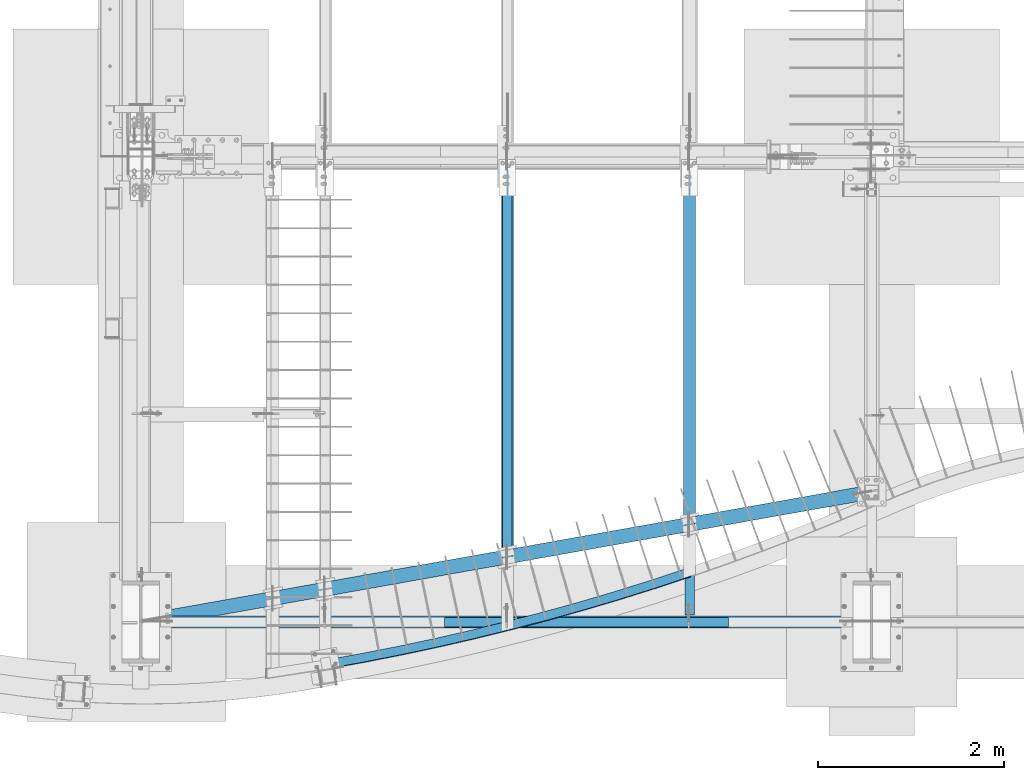
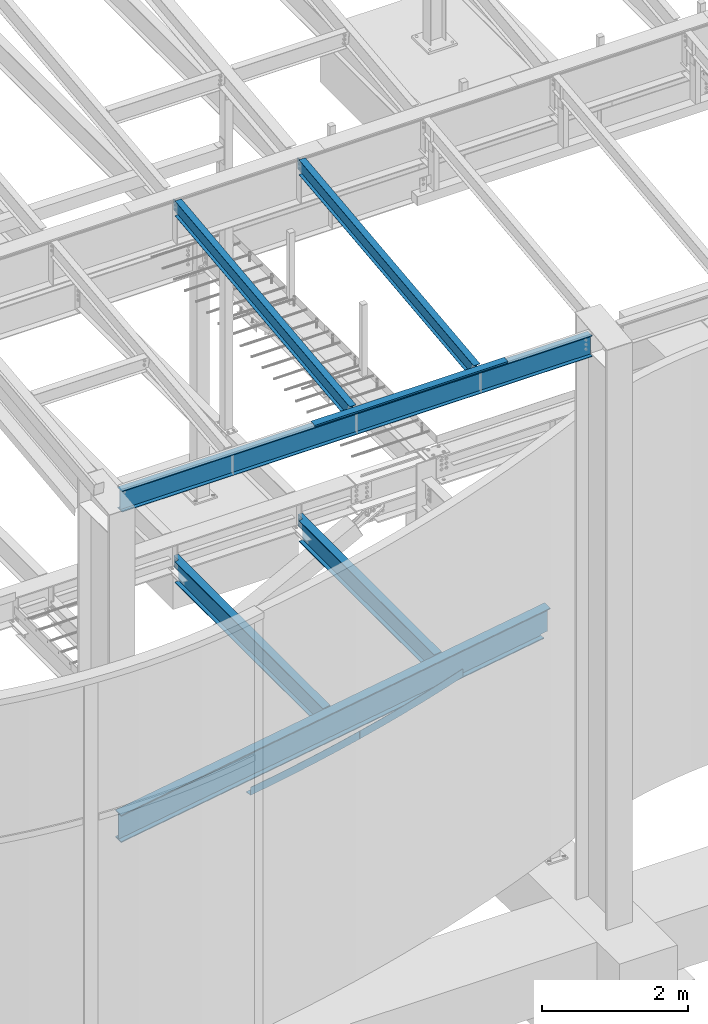
# One storey, part 703 of 1179: 9 beams, 8 elements without a shape of their own.
"""IFC2X3 building model written with IfcOpenShell, lengths in millimetres."""

from ifc_helpers import new_model, si_unit, frame, origin_with_axes, place, context, subcontext, project, spatial, faceted_brep, material, type_object, element, aggregate, save


model = new_model("IFC2X3")

# Units and contexts
model_context = context("Model", 3, precision=1e-05, world=origin_with_axes())
body_context = subcontext(model_context, "Body", "Model", "MODEL_VIEW")
ifc_project = project(units=[si_unit("LENGTHUNIT", "METRE", prefix="MILLI"), si_unit("AREAUNIT", "SQUARE_METRE"), si_unit("VOLUMEUNIT", "CUBIC_METRE"), si_unit("MASSUNIT", "GRAM", prefix="KILO"), si_unit("TIMEUNIT", "SECOND"), si_unit("PLANEANGLEUNIT", "RADIAN"), si_unit("SOLIDANGLEUNIT", "STERADIAN"), si_unit("THERMODYNAMICTEMPERATUREUNIT", "DEGREE_CELSIUS"), si_unit("LUMINOUSINTENSITYUNIT", "LUMEN")], contexts=[model_context])

# Site, building, storey
site_placement = place(None, origin_with_axes())
site = spatial("IfcSite", under=ifc_project, at=site_placement, CompositionType="ELEMENT")
building_placement = place(site_placement, origin_with_axes())
building = spatial("IfcBuilding", under=site, at=building_placement, Name="Undefined", CompositionType="ELEMENT")
storey_placement = place(building_placement, origin_with_axes())
storey = spatial("IfcBuildingStorey", under=building, at=storey_placement, Name="Undefined", CompositionType="ELEMENT", Elevation=0.0)

# Assembly, beam
assembly_1_placement = place(storey_placement, origin_with_axes())
assembly_1 = element("IfcElementAssembly", 1, at=assembly_1_placement, inside=storey, Name="BEAM", AssemblyPlace="NOTDEFINED", PredefinedType="RIGID_FRAME")
ifc_material_1 = material(Name="STEEL/A992")
beam_type_1 = type_object("IfcBeamType", Name="W10X12", PredefinedType="NOTDEFINED")
beam_1_placement = place(assembly_1_placement, frame((6324.6, 452.231593993459, 9171.78056384809), z_axis=(-3.89779463887408e-08, -0.112282221021699, 0.993676357192035), x_axis=(0.0, 0.993676357192036, 0.112282221021699)))
beam_1 = element("IfcBeam", 2, at=beam_1_placement, type_object=beam_type_1, material=ifc_material_1, Name="BEAM", ObjectType="W10X12", context=body_context, shape_type="Brep", body=[
    faceted_brep([(4857.69134886906, 2.38125000000036, -120.649999999367), (4857.69134886908, 2.38119321150953, -125.412499999362), (4857.69133715173, 50.7999999999993, -125.412499999366), (4857.69133715173, 50.7999999999993, -120.649999999367), (4982.28709465017, 2.38125000000036, -120.649999999352), (4981.74894752234, 2.38122323349126, -125.412499999349), (48.8806597554974, -2.38124999999854, -120.649999999914), (48.8806597554974, -50.7999999999993, -120.649999999914), (4857.69136171279, -50.7999999999993, -120.649999999368), (4857.69134999544, -2.38125000000036, -120.649999999367), (76.1467808989316, 2.38124999999854, 120.649999999929), (76.1467808989316, 50.7999999999993, 120.649999999929), (4881.74500230402, 50.7999999999993, 120.650000000474), (4881.74500230402, 2.38125000000036, 120.650000000474), (48.3425126276663, -50.7999999999993, -125.412499999911), (76.1467808989316, -2.38124999999854, 120.649999999929), (76.1467808989316, -50.7999999999993, 120.649999999929), (76.6849280267622, -50.7999999999993, 125.412499999924), (76.6849280267622, 50.7999999999993, 125.412499999924), (48.8806597554974, 2.38124999999854, -120.649999999914), (48.8806597554974, 50.7999999999993, -120.649999999914), (48.3425126276663, 50.7999999999993, -125.412499999911), (4857.69136171279, -50.7999999999993, -125.412499999366), (4857.69134999547, -2.38130675233151, -125.412499999364), (4982.28709465017, -2.38125000000036, -120.649999999352), (4981.74894752234, -2.38127673034069, -125.412499999349), (4884.49824407442, -2.38125000000036, 75.1923220895023), (4880.7132366458, -2.38125000000036, 78.3905494782684), (4878.44025438672, -2.38125000000036, 82.793785937376), (4878.02533824148, -2.38125000000036, 87.7316786313622), (4881.74500230402, -2.38125000000036, 120.650000000474), (4982.37312427097, -2.38125000000036, -119.888654174249), (5002.79625141886, -2.38125000000036, 60.8521470148644), (4889.21904360274, -2.38125000000036, 73.6860048990093), (4881.74500230402, -50.7999999999993, 120.650000000474), (4882.28314943185, -50.7999999999993, 125.41250000047), (4882.28314943185, 50.7999999999993, 125.41250000047), (4878.02533824148, 2.38125000000036, 87.7316786313622), (4878.44025438672, 2.38125000000036, 82.793785937376), (4880.7132366458, 2.38125000000036, 78.3905494782684), (4884.49824407442, 2.38125000000036, 75.1923220895023), (4889.21904360274, 2.38125000000036, 73.6860048990093), (5002.79625141886, 2.38125000000036, 60.8521470148644), (4982.37311143735, 2.38125000000036, -119.888767749362)], [[[0, 1, 2, 3]], [[4, 5, 1, 0]], [[6, 7, 8, 9]], [[10, 11, 12, 13]], [[14, 7, 6, 15, 16, 17, 18, 11, 10, 19, 20, 21]], [[7, 14, 22, 8]], [[8, 22, 23, 9]], [[24, 9, 23, 25]], [[26, 27, 28, 29, 30, 15, 6, 9, 24, 31, 32, 33]], [[16, 15, 30, 34]], [[17, 16, 34, 35]], [[18, 17, 35, 36]], [[11, 18, 36, 12]], [[35, 34, 30, 29, 37, 13, 12, 36]], [[28, 38, 37, 29]], [[27, 39, 38, 28]], [[26, 40, 39, 27]], [[33, 41, 40, 26]], [[32, 42, 41, 33]], [[43, 4, 0, 19, 10, 13, 37, 38, 39, 40, 41, 42]], [[20, 19, 0, 3]], [[21, 20, 3, 2]], [[25, 23, 22, 14, 21, 2, 1, 5]], [[43, 42, 32, 31, 24, 25, 5, 4]]]),
])
aggregate(assembly_1, [beam_1])

assembly_2_placement = place(storey_placement, origin_with_axes())
assembly_2 = element("IfcElementAssembly", 3, at=assembly_2_placement, inside=storey, Name="BEAM", AssemblyPlace="NOTDEFINED", PredefinedType="RIGID_FRAME")
beam_2_placement = place(assembly_2_placement, frame((4368.8, 452.231593993459, 9171.78056384809), z_axis=(-3.89779463887408e-08, -0.112282221021699, 0.993676357192035), x_axis=(0.0, 0.993676357192036, 0.112282221021699)))
beam_2 = element("IfcBeam", 4, at=beam_2_placement, type_object=beam_type_1, material=ifc_material_1, Name="BEAM", ObjectType="W10X12", context=body_context, shape_type="Brep", body=[
    faceted_brep([(4857.69134886906, 2.38125000000036, -120.649999999367), (4857.69134886908, 2.38119321150953, -125.412499999362), (4857.69133715173, 50.7999999999993, -125.412499999366), (4857.69133715173, 50.7999999999993, -120.649999999367), (4982.21285105545, 2.38125000000036, -120.649999999354), (4981.67470392712, 2.38122321723404, -125.412499999351), (48.8806597554974, -2.38124999999854, -120.649999999914), (48.8806597554974, -50.7999999999993, -120.649999999914), (4857.69136171279, -50.7999999999993, -120.649999999368), (4857.69134999544, -2.38125000000036, -120.649999999367), (76.1467808989316, 2.38124999999854, 120.649999999929), (76.1467808989316, 50.7999999999993, 120.649999999929), (4881.74500230402, 50.7999999999993, 120.650000000474), (4881.74500230402, 2.38125000000036, 120.650000000474), (48.3425126276663, -50.7999999999993, -125.412499999911), (76.1467808989316, -2.38124999999854, 120.649999999929), (76.1467808989316, -50.7999999999993, 120.649999999929), (76.6849280267622, -50.7999999999993, 125.412499999924), (76.6849280267622, 50.7999999999993, 125.412499999924), (48.8806597554974, 2.38124999999854, -120.649999999914), (48.8806597554974, 50.7999999999993, -120.649999999914), (48.3425126276663, 50.7999999999993, -125.412499999911), (4857.69136171279, -50.7999999999993, -125.412499999366), (4857.69134999547, -2.38130675233151, -125.412499999364), (4982.2127611903, -2.38125000000036, -120.649999999354), (4981.67461406197, -2.38127674617681, -125.412499999351), (4884.49824407442, -2.38125000000036, 75.1923220895023), (4880.7132366458, -2.38125000000036, 78.3905494782684), (4878.44025438672, -2.38125000000036, 82.793785937376), (4878.02533824148, -2.38125000000036, 87.7316786313622), (4881.74500230402, -2.38125000000036, 120.650000000474), (4982.29879081109, -2.38125000000036, -119.88865417433), (5002.72285510301, -2.38125000000036, 60.8604405616497), (4889.21904360274, -2.38125000000036, 73.6860048990093), (4881.74500230402, -50.7999999999993, 120.650000000474), (4882.28314943185, -50.7999999999993, 125.41250000047), (4882.28314943185, 50.7999999999993, 125.41250000047), (4878.02533824148, 2.38125000000036, 87.7316786313622), (4878.44025438672, 2.38125000000036, 82.793785937376), (4880.7132366458, 2.38125000000036, 78.3905494782684), (4884.49824407442, 2.38125000000036, 75.1923220895023), (4889.21904360274, 2.38125000000036, 73.6860048990093), (5002.72294383521, 2.38125000000036, 60.8604305351982), (4982.29886784264, 2.38125000000036, -119.888767749235)], [[[0, 1, 2, 3]], [[4, 5, 1, 0]], [[6, 7, 8, 9]], [[10, 11, 12, 13]], [[14, 7, 6, 15, 16, 17, 18, 11, 10, 19, 20, 21]], [[7, 14, 22, 8]], [[8, 22, 23, 9]], [[24, 9, 23, 25]], [[26, 27, 28, 29, 30, 15, 6, 9, 24, 31, 32, 33]], [[16, 15, 30, 34]], [[17, 16, 34, 35]], [[18, 17, 35, 36]], [[11, 18, 36, 12]], [[35, 34, 30, 29, 37, 13, 12, 36]], [[28, 38, 37, 29]], [[27, 39, 38, 28]], [[26, 40, 39, 27]], [[33, 41, 40, 26]], [[32, 42, 41, 33]], [[43, 4, 0, 19, 10, 13, 37, 38, 39, 40, 41, 42]], [[20, 19, 0, 3]], [[21, 20, 3, 2]], [[25, 23, 22, 14, 21, 2, 1, 5]], [[43, 42, 32, 31, 24, 25, 5, 4]]]),
])
aggregate(assembly_2, [beam_2])

# Assembly, beams
assembly_3_placement = place(storey_placement, origin_with_axes())
assembly_3 = element("IfcElementAssembly", 5, at=assembly_3_placement, inside=storey, Name="BEAM", AssemblyPlace="NOTDEFINED", PredefinedType="RIGID_FRAME")
beam_type_2 = type_object("IfcBeamType", Name="W14X22", PredefinedType="NOTDEFINED")
beam_3_placement = place(assembly_3_placement, frame((431.800000000001, 438.14999988271, 9090.62031305009), z_axis=(0.0, 0.0, 1.0), x_axis=(1.0, 0.0, 0.0)))
beam_3 = element("IfcBeam", 6, at=beam_3_placement, type_object=beam_type_2, material=ifc_material_1, Name="BEAM", ObjectType="W14X22", context=body_context, shape_type="Brep", body=[
    faceted_brep([(212.725000000002, -63.5, -174.625), (212.725000000002, 63.5, -174.625), (7635.875, 63.5, -174.625), (7635.875, -63.5, -174.625), (212.725000000002, -63.5, -166.6875), (212.725000000002, -3.17500000000001, -166.6875), (212.725000000002, -3.17500000000001, 166.6875), (212.725000000002, -63.5, 166.6875), (212.725000000002, -63.5, 174.625), (212.725000000002, 63.5, 174.625), (212.725000000002, 63.5, 166.6875), (212.725000000002, 3.17500000000001, 166.6875), (212.725000000002, 3.17500000000001, 137.265000000092), (212.725000000002, 3.17500000000001, -92.8149999999841), (212.725000000002, 3.17500000000001, -166.6875), (212.725000000002, 63.5, -166.6875), (7635.875, -63.5, -166.6875), (7635.875, -3.17500000000001, -166.6875), (7635.875, -3.17500000000001, 166.6875), (7635.875, -63.5, 166.6875), (7635.875, -63.5, 174.625), (7635.875, 63.5, 174.625), (7635.875, 63.5, 166.6875), (7635.875, 3.17500000000001, 166.6875), (7635.875, 3.17500000000001, 137.26500000009), (7635.875, 3.17500000000001, -92.814999999986), (7635.875, 3.17500000000001, -166.6875), (7635.875, 63.5, -166.6875)], [[[0, 1, 2, 3]], [[0, 4, 5, 6, 7, 8, 9, 10, 11, 12, 13, 14, 15, 1]], [[5, 4, 16, 17]], [[6, 5, 17, 18]], [[7, 6, 18, 19]], [[8, 7, 19, 20]], [[9, 8, 20, 21]], [[10, 9, 21, 22]], [[11, 10, 22, 23]], [[14, 13, 12, 11, 23, 24, 25, 26]], [[15, 14, 26, 27]], [[1, 15, 27, 2]], [[26, 25, 24, 23, 22, 21, 20, 19, 18, 17, 16, 3, 2, 27]], [[4, 0, 3, 16]]]),
])
ifc_material_2 = material(Name="STEEL/A36")
beam_type_3 = type_object("IfcBeamType", PredefinedType="NOTDEFINED")
beam_4_placement = place(assembly_3_placement, frame((5216.52499999948, 485.774999119674, 9265.24531303919), z_axis=(-1.0, 0.0, 0.0), x_axis=(0.0, 0.0, 1.0)))
beam_4 = element("IfcBeam", 7, at=beam_4_placement, type_object=beam_type_3, material=ifc_material_2, Name="BENT_PLATE", context=body_context, shape_type="Brep", body=[
    faceted_brep([(0.0, -3.17499999999927, -1524.0), (6.00266503170133e-10, -3.17499999922438, 1524.00000000052), (6.00266503170133e-10, 3.17500000077416, 1524.00000000052), (0.0, 3.17499999999927, -1524.0), (36.8806648358295, 3.17499999974928, 1524.0), (36.8806648358295, 3.17499999974928, -1524.0), (29.7727112184712, -3.17500000020243, -1524.0), (29.7727112184712, -3.17500000020243, 1524.0), (25.3999996289767, -98.4249984738682, 1524.0), (25.3999996289767, -98.4249984738682, -1524.0), (19.7271291840298, -92.0749984738682, -1524.0), (19.7271291840298, -92.0749984738682, 1524.0), (2.13476596400142e-08, -98.4249984738682, 1524.0), (2.13476596400142e-08, -98.4249984738682, -1524.0), (2.13476596400142e-08, -92.0749984738682, 1524.0), (2.13476596400142e-08, -92.0749984738682, -1524.0)], [[[0, 1, 2, 3]], [[3, 2, 4, 5]], [[1, 0, 6, 7]], [[5, 4, 8, 9]], [[7, 6, 10, 11]], [[9, 8, 12, 13]], [[8, 4, 2, 1, 7, 11, 14, 12]], [[11, 10, 15, 14]], [[10, 6, 0, 3, 5, 9, 13, 15]], [[14, 15, 13, 12]]]),
])
aggregate(assembly_3, [beam_4, beam_3])

# Assembly, beam
assembly_4_placement = place(storey_placement, origin_with_axes())
assembly_4 = element("IfcElementAssembly", 8, at=assembly_4_placement, inside=storey, Name="BENT_PLATE", AssemblyPlace="NOTDEFINED", PredefinedType="RIGID_FRAME")
beam_type_4 = type_object("IfcBeamType", PredefinedType="NOTDEFINED")
beam_5_placement = place(assembly_4_placement, frame((6323.84832429739, 970.884356906327, 3914.775), z_axis=(0.0, 0.0, 1.0), x_axis=(-0.953106622003924, -0.302634709001246, 0.0)))
beam_5 = element("IfcBeam", 9, at=beam_5_placement, type_object=beam_type_4, material=ifc_material_2, Name="BENT_PLATE", context=body_context, shape_type="Brep", body=[
    faceted_brep([(2.09069352193728, -50.7784868985931, -66.6750000000002), (2.09069352193728, -50.7784868985931, -60.3249999999998), (0.130668347676874, 44.4513445688322, -60.3249999999998), (0.130668347676874, 44.4513445688322, 66.6750000000002), (6.91215973347425e-11, 50.8000000000129, 66.6750000000002), (6.91215973347425e-11, 50.8000000000129, -66.6750000000002), (816.862073633947, 47.8129313178124, 66.6750000000002), (1225.15859990912, 39.4094029986059, 66.6750000000002), (1633.26145200235, 24.2854230343255, 66.6750000000002), (2041.060020578, 2.4450905224578, 66.6750000000002), (2041.4518026996, 8.78299291750534, 66.6750000000002), (1633.54884317471, 30.6289162607762, 66.6750000000002), (1225.34152223975, 45.7567677605318, 66.6750000000002), (816.940477544864, 54.1624472699723, 66.6750000000002), (408.45639924569, 55.8436765726599, 66.6750000000002), (408.482535004532, 49.4937303585505, 66.6750000000002), (408.45639924569, 55.8436765726599, -66.6750000000002), (816.940477544865, 54.1624472699723, -66.6750000000002), (1225.34152223975, 45.7567677605318, -66.6750000000002), (1633.54884317471, 30.6289162607762, -66.6750000000002), (2041.4518026996, 8.78299291750534, -66.6750000000002), (2035.18328875403, -92.6234454033024, -66.6750000000002), (1628.95058441697, -70.8669753624544, -66.6750000000002), (1222.41476494967, -55.8010684302947, -66.6750000000002), (815.686014970197, -47.4298079645998, -66.6750000000002), (408.874571387183, -45.7554628531115, -66.6750000000002), (408.874571387183, -45.7554628531115, -60.3249999999998), (815.686014970197, -47.4298079645998, -60.3249999999998), (1222.41476494967, -55.8010684302947, -60.3249999999998), (1628.95058441697, -70.8669753624544, -60.3249999999998), (2035.18328875403, -92.6234454033024, -60.3249999999998), (2041.060020578, 2.4450905224578, -60.3249999999998), (1633.26145200235, 24.2854230343255, -60.3249999999998), (1225.15859990912, 39.4094029986059, -60.3249999999998), (816.862073633947, 47.8129313178124, -60.3249999999998), (408.482535004532, 49.4937303585505, -60.3249999999998)], [[[0, 1, 2, 3, 4, 5]], [[6, 7, 8, 9, 10, 11, 12, 13, 14, 4, 3, 15]], [[5, 4, 14, 16]], [[17, 18, 19, 20, 21, 22, 23, 24, 25, 0, 5, 16]], [[1, 0, 25, 26]], [[27, 28, 29, 30, 31, 32, 33, 34, 35, 2, 1, 26]], [[3, 2, 35, 15]], [[35, 34, 6, 15]], [[25, 24, 27, 26]], [[14, 13, 17, 16]], [[34, 33, 7, 6]], [[24, 23, 28, 27]], [[13, 12, 18, 17]], [[33, 32, 8, 7]], [[23, 22, 29, 28]], [[12, 11, 19, 18]], [[9, 31, 30, 21, 20, 10]], [[32, 31, 9, 8]], [[22, 21, 30, 29]], [[11, 10, 20, 19]]]),
])
aggregate(assembly_4, [beam_5])

assembly_5_placement = place(storey_placement, origin_with_axes())
assembly_5 = element("IfcElementAssembly", 10, at=assembly_5_placement, inside=storey, Name="BENT_PLATE", AssemblyPlace="NOTDEFINED", PredefinedType="RIGID_FRAME")
beam_6_placement = place(assembly_5_placement, frame((4363.13687958384, 392.628235001748, 3914.7747997099), z_axis=(0.0, 0.0, 1.0), x_axis=(-0.974079105665056, -0.226207638922217, 0.0)))
beam_6 = element("IfcBeam", 11, at=beam_6_placement, type_object=beam_type_4, material=ifc_material_2, Name="BENT_PLATE", context=body_context, shape_type="Brep", body=[
    faceted_brep([(1.96794011685688, -50.7809392147853, -66.6750000000002), (1.96794011685688, -50.7809392147853, -60.3249999999998), (0.12299627178345, 44.4511912990799, -60.3249999999998), (0.12299627178345, 44.4511912990799, 66.6750000000002), (6.91215973347425e-11, 50.8000000000129, 66.6750000000002), (6.91215973347425e-11, 50.8000000000129, -66.6750000000002), (800.864280475816, 47.5533291491543, 66.6750000000002), (1201.17482955032, 39.7979863480425, 66.6750000000002), (1601.31713621931, 25.8403556066162, 66.6750000000002), (2001.19510992353, 5.68378872377059, 66.6750000000002), (2001.56391654927, 12.0230695720053, 66.6750000000002), (1601.58766495761, 32.1845903281351, 66.6750000000002), (1201.34701543615, 46.1456514322053, 66.6750000000002), (800.938082160285, 53.9029002615481, 66.6750000000002), (400.457019717253, 55.4544739829514, 66.6750000000002), (400.481619956951, 49.1045216344547, 66.6750000000002), (400.457019717253, 55.4544739829514, -66.6750000000002), (800.938082160285, 53.9029002615481, -66.6750000000002), (1201.34701543615, 46.1456514322053, -66.6750000000002), (1601.58766495761, 32.1845903281351, -66.6750000000002), (2001.56391654927, 12.0230695720053, -66.6750000000002), (1995.66301053739, -89.4054239997716, -66.6750000000002), (1597.25920514481, -69.3231652162068, -66.6750000000002), (1198.59204126292, -55.4169899144317, -66.6750000000002), (799.757255208793, -47.6902375367869, -66.6750000000002), (400.850623552415, -46.1447635930364, -66.6750000000002), (400.850623552415, -46.1447635930364, -60.3249999999998), (799.757255208793, -47.6902375367869, -60.3249999999998), (1198.59204126292, -55.4169899144317, -60.3249999999998), (1597.25920514481, -69.3231652162068, -60.3249999999998), (1995.66301053739, -89.4054239997716, -60.3249999999998), (2001.19510992353, 5.68378872377059, -60.3249999999998), (1601.31713621931, 25.8403556066162, -60.3249999999998), (1201.17482955032, 39.7979863480425, -60.3249999999998), (800.864280475816, 47.5533291491543, -60.3249999999998), (400.481619956951, 49.1045216344547, -60.3249999999998)], [[[0, 1, 2, 3, 4, 5]], [[6, 7, 8, 9, 10, 11, 12, 13, 14, 4, 3, 15]], [[5, 4, 14, 16]], [[17, 18, 19, 20, 21, 22, 23, 24, 25, 0, 5, 16]], [[1, 0, 25, 26]], [[27, 28, 29, 30, 31, 32, 33, 34, 35, 2, 1, 26]], [[3, 2, 35, 15]], [[35, 34, 6, 15]], [[25, 24, 27, 26]], [[14, 13, 17, 16]], [[34, 33, 7, 6]], [[24, 23, 28, 27]], [[13, 12, 18, 17]], [[33, 32, 8, 7]], [[23, 22, 29, 28]], [[12, 11, 19, 18]], [[9, 31, 30, 21, 20, 10]], [[32, 31, 9, 8]], [[22, 21, 30, 29]], [[11, 10, 20, 19]]]),
])
aggregate(assembly_5, [beam_6])

assembly_6_placement = place(storey_placement, origin_with_axes())
assembly_6 = element("IfcElementAssembly", 12, at=assembly_6_placement, inside=storey, Name="BEAM", AssemblyPlace="NOTDEFINED", PredefinedType="RIGID_FRAME")
beam_type_5 = type_object("IfcBeamType", Name="W14X26", PredefinedType="NOTDEFINED")
beam_7_placement = place(assembly_6_placement, frame((6324.60000217468, 1486.96639397681, 3671.8875), z_axis=(0.0, 0.0, 1.0), x_axis=(0.0, 1.0, 0.0)))
beam_7 = element("IfcBeam", 13, at=beam_7_placement, type_object=beam_type_5, material=ifc_material_1, Name="BEAM", ObjectType="W14X26", context=body_context, shape_type="Brep", body=[
    faceted_brep([(3781.94610461694, -3.17499999864049, -165.1), (3781.94610461696, -63.4999999986403, -165.1), (3781.94610461696, -63.4999999986403, -176.2125), (3781.94610461692, 28.5750065473112, -176.2125), (3781.94610461692, 28.5750065473112, -165.1), (3781.94610461694, 3.17500000135897, -165.1), (3781.94610461691, 3.17500000135897, -33.3374996185316), (3781.94610461691, -3.17499999864049, -33.3374996185316), (3783.87956446209, 3.17500000135988, -23.6173405824406), (3783.87956446209, -3.17499999864049, -23.6173405824406), (3789.38559226304, 3.1750000013626, -15.3769876461333), (3789.38559226304, -3.17499999863776, -15.3769876461333), (3797.62594519935, 3.17500000136533, -9.87095984517691), (3797.62594519935, -3.17499999863412, -9.87095984517691), (3807.34610423544, 3.17500000136897, -7.93750000000136), (3807.34610423544, -3.17499999863139, -7.93750000000136), (3916.88360461691, -3.17499999859228, -7.93750000000136), (3916.88360156516, 3.17500000140808, -7.93750000000136), (3916.88360156512, -63.4999999985921, 165.1), (3916.88360156512, -63.4999999985921, 176.2125), (105.35615323098, -63.5, 176.2125), (98.8397136083431, -63.5, 165.1), (3916.88360156516, 3.17500692884096, 176.2125), (3916.88360156516, 3.17500000140808, 165.1), (3807.34610423544, 3.17500000136897, 165.1), (3807.34610423544, 3.17500692880185, 176.2125), (3797.62594519935, 5.10846677396967, 176.2125), (3789.38559226305, 10.6144945749193, 176.2125), (3783.87956446209, 18.854847511222, 176.2125), (3781.94610461692, 28.5750065473112, 176.2125), (3781.94610461692, 63.5000000013597, 176.2125), (82.7523516449764, 63.5, 176.2125), (76.23591202234, 63.5, 165.1), (3781.94610461692, 63.5000000013597, 165.1), (3781.94610461692, 28.5750065473112, 165.1), (3783.87956446209, 18.854847511222, 165.1), (3789.38559226305, 10.6144945749193, 165.1), (3797.62594519935, 5.10846677396967, 165.1), (86.9727177756913, 3.17499999999995, 165.1), (32.3299982146518, -63.5, -165.1), (21.5931924613005, -3.17499999999995, -165.1), (21.8259821526158, -3.17499999999995, -164.703000259399), (20.6957920733156, 3.17499999999995, -164.703000259399), (20.463002382, 3.17499999999995, -165.1), (9.72619662864872, 63.5, -165.1), (3.21013331628819, 63.5, -176.2125), (25.8139349022913, -63.5, -176.2125), (38.1832580331089, -3.17499999999995, -164.703000259399), (37.0530679538094, 3.17499999999995, -164.703000259399), (54.7689134870706, -3.17499999999995, -158.045004848507), (53.6387234077712, 3.17499999999995, -158.045004848507), (58.9178459884611, -3.17499999999995, -154.857742002601), (57.7876559091617, 3.17499999999995, -154.857742002601), (60.7584206939351, -3.17499999999995, -150.003873155929), (59.6282306146358, 3.17499999999995, -150.003873155929), (59.7460515670933, -3.17499999999995, -144.919552564306), (58.6158614877939, 3.17499999999995, -144.919552564306), (56.1802766209923, -3.17499999999995, -141.10912014425), (55.0500865416928, 3.17499999999995, -141.10912014425), (51.1161311328278, -3.17499999999995, -139.7), (49.9859410535283, 3.17499999999995, -139.7), (18.3020261524669, -3.17499999999995, -139.7), (17.1718360731667, 3.17499999999995, -139.7), (18.3020261524669, -3.17499999999995, 139.7), (17.1718360731667, 3.17499999999995, 139.7), (123.376362989785, -3.17499999999995, 139.7), (122.246172910485, 3.17499999999995, 139.7), (128.440508477951, -3.17499999999995, 141.10912014425), (127.310318398651, 3.17499999999995, 141.10912014425), (132.006283424052, -3.17499999999995, 144.919552564306), (130.876093344752, 3.17499999999995, 144.919552564306), (133.018652550893, -3.17499999999995, 150.003873155928), (131.888462471594, 3.17499999999995, 150.003873155928), (131.178077845419, -3.17499999999995, 154.857742002601), (130.04788776612, 3.17499999999995, 154.857742002601), (127.029145344027, -3.17499999999995, 158.045004848507), (125.898955264728, 3.17499999999995, 158.045004848507), (110.443489890066, -3.17499999999995, 164.703000259399), (109.313299810766, 3.17499999999995, 164.703000259399), (87.8701047197993, -3.17499999999995, 164.703000259399), (86.739914640499, 3.17499999999995, 164.703000259399), (88.1029078549918, -3.17499999999995, 165.1), (3916.88360156515, -3.17499999859228, 165.1), (3781.94610461692, 63.5000000013597, -165.1), (3781.94610461692, 63.5000000013597, -176.2125)], [[[0, 1, 2, 3, 4, 5, 6, 7]], [[7, 6, 8, 9]], [[9, 8, 10, 11]], [[11, 10, 12, 13]], [[13, 12, 14, 15]], [[16, 15, 14, 17]], [[18, 19, 20, 21]], [[22, 23, 24, 25]], [[26, 27, 28, 29, 30, 31, 20, 19, 22, 25]], [[32, 31, 30, 33]], [[29, 34, 33, 30]], [[28, 35, 34, 29]], [[27, 36, 35, 28]], [[26, 37, 36, 27]], [[25, 24, 37, 26]], [[38, 32, 33, 34, 35, 36, 37, 24]], [[39, 40, 41, 42, 43, 44, 45, 46]], [[47, 48, 42, 41]], [[49, 50, 48, 47]], [[51, 52, 50, 49]], [[53, 54, 52, 51]], [[55, 56, 54, 53]], [[57, 58, 56, 55]], [[59, 60, 58, 57]], [[60, 59, 61, 62]], [[63, 64, 62, 61]], [[65, 66, 64, 63]], [[67, 68, 66, 65]], [[69, 70, 68, 67]], [[71, 72, 70, 69]], [[73, 74, 72, 71]], [[75, 76, 74, 73]], [[77, 78, 76, 75]], [[78, 77, 79, 80]], [[20, 31, 32, 38, 80, 79, 81, 21]], [[82, 18, 21, 81]], [[23, 22, 19, 18, 82, 16, 17]], [[12, 10, 8, 6, 5, 43, 42, 48, 50, 52, 54, 56, 58, 60, 62, 64, 66, 68, 70, 72, 74, 76, 78, 80, 38, 24, 23, 17, 14]], [[83, 44, 43, 5, 4]], [[45, 44, 83, 84]], [[4, 3, 84, 83]], [[46, 45, 84, 3, 2]], [[39, 46, 2, 1]], [[40, 39, 1, 0]], [[82, 81, 79, 77, 75, 73, 71, 69, 67, 65, 63, 61, 59, 57, 55, 53, 51, 49, 47, 41, 40, 0, 7, 9, 11, 13, 15, 16]]]),
])
aggregate(assembly_6, [beam_7])

assembly_7_placement = place(storey_placement, origin_with_axes())
assembly_7 = element("IfcElementAssembly", 14, at=assembly_7_placement, inside=storey, Name="BEAM", AssemblyPlace="NOTDEFINED", PredefinedType="RIGID_FRAME")
beam_8_placement = place(assembly_7_placement, frame((4368.79999869724, 1138.86784893505, 3671.8875), z_axis=(0.0, 0.0, 1.0), x_axis=(0.0, 1.0, 0.0)))
beam_8 = element("IfcBeam", 15, at=beam_8_placement, type_object=beam_type_5, material=ifc_material_1, Name="BEAM", ObjectType="W14X26", context=body_context, shape_type="Brep", body=[
    faceted_brep([(4130.04465411671, -3.17500000000018, -165.1), (4130.04465411671, -63.5, -165.1), (4130.04465411671, -63.5, -176.2125), (4130.04465411671, 28.5749983157712, -176.2125), (4130.04465411671, 28.5749983157712, -165.1), (4130.04465411671, 3.17500000000018, -165.1), (4130.04465411671, 3.17500000000018, -33.3374996185316), (4130.04465411671, -3.17500000000018, -33.3374996185316), (4131.97811396188, 3.17500000000018, -23.6173405824406), (4131.97811396188, -3.17500000000018, -23.6173405824406), (4137.48414176284, 3.17500000000018, -15.3769876461333), (4137.48414176284, -3.17500000000018, -15.3769876461333), (4145.72449469914, 3.17500000000018, -9.87095984517691), (4145.72449469914, -3.17500000000018, -9.87095984517691), (4155.44465373524, 3.17500000000018, -7.93750000000136), (4155.44465373524, -3.17500000000018, -7.93750000000136), (4264.98215411671, -3.17500000000018, -7.93750000000136), (4264.98215106495, 3.17500000000018, -7.93750000000136), (4264.98215106495, -63.5, 165.1), (4264.98215106495, -63.5, 176.2125), (105.35615323098, -63.5, 176.2125), (98.8397136083431, -63.5, 165.1), (4264.98215106495, 3.17499869724088, 176.2125), (4264.98215106495, 3.17500000000018, 165.1), (4155.44465373524, 3.17500000000018, 165.1), (4155.44465373524, 3.17499869724088, 176.2125), (4145.72449469914, 5.10845854241688, 176.2125), (4137.48414176284, 10.6144863433728, 176.2125), (4131.97811396188, 18.8548392796802, 176.2125), (4130.04465411671, 28.5749983157712, 176.2125), (4130.04465411671, 63.5, 176.2125), (82.7523516449764, 63.5, 176.2125), (76.23591202234, 63.5, 165.1), (4130.04465411671, 63.5, 165.1), (4130.04465411671, 28.5749983157712, 165.1), (4131.97811396188, 18.8548392796802, 165.1), (4137.48414176284, 10.6144863433728, 165.1), (4145.72449469914, 5.10845854241688, 165.1), (86.9727177756913, 3.17499999999995, 165.1), (32.3299982146518, -63.5, -165.1), (21.5931924613005, -3.17499999999995, -165.1), (21.8259821526158, -3.17499999999995, -164.703000259399), (20.6957920733156, 3.17499999999995, -164.703000259399), (20.463002382, 3.17499999999995, -165.1), (9.72619662864872, 63.5, -165.1), (3.21013331628819, 63.5, -176.2125), (25.8139349022913, -63.5, -176.2125), (38.1832580331089, -3.17499999999995, -164.703000259399), (37.0530679538094, 3.17499999999995, -164.703000259399), (54.7689134870706, -3.17499999999995, -158.045004848507), (53.6387234077712, 3.17499999999995, -158.045004848507), (58.9178459884611, -3.17499999999995, -154.857742002601), (57.7876559091617, 3.17499999999995, -154.857742002601), (60.7584206939351, -3.17499999999995, -150.003873155929), (59.6282306146358, 3.17499999999995, -150.003873155929), (59.7460515670933, -3.17499999999995, -144.919552564306), (58.6158614877939, 3.17499999999995, -144.919552564306), (56.1802766209923, -3.17499999999995, -141.10912014425), (55.0500865416928, 3.17499999999995, -141.10912014425), (51.1161311328278, -3.17499999999995, -139.7), (49.9859410535283, 3.17499999999995, -139.7), (18.3020261524669, -3.17499999999995, -139.7), (17.1718360731667, 3.17499999999995, -139.7), (18.3020261524669, -3.17499999999995, 139.7), (17.1718360731667, 3.17499999999995, 139.7), (123.376362989785, -3.17499999999995, 139.7), (122.246172910485, 3.17499999999995, 139.7), (128.440508477951, -3.17499999999995, 141.10912014425), (127.310318398651, 3.17499999999995, 141.10912014425), (132.006283424052, -3.17499999999995, 144.919552564306), (130.876093344752, 3.17499999999995, 144.919552564306), (133.018652550893, -3.17499999999995, 150.003873155928), (131.888462471594, 3.17499999999995, 150.003873155928), (131.178077845419, -3.17499999999995, 154.857742002601), (130.04788776612, 3.17499999999995, 154.857742002601), (127.029145344027, -3.17499999999995, 158.045004848507), (125.898955264728, 3.17499999999995, 158.045004848507), (110.443489890066, -3.17499999999995, 164.703000259399), (109.313299810766, 3.17499999999995, 164.703000259399), (87.8701047197993, -3.17499999999995, 164.703000259399), (86.739914640499, 3.17499999999995, 164.703000259399), (88.1029078549918, -3.17499999999995, 165.1), (4264.98215106495, -3.17500000000018, 165.1), (4130.04465411671, 63.5, -165.1), (4130.04465411671, 63.5, -176.2125)], [[[0, 1, 2, 3, 4, 5, 6, 7]], [[7, 6, 8, 9]], [[9, 8, 10, 11]], [[11, 10, 12, 13]], [[13, 12, 14, 15]], [[16, 15, 14, 17]], [[18, 19, 20, 21]], [[22, 23, 24, 25]], [[26, 27, 28, 29, 30, 31, 20, 19, 22, 25]], [[32, 31, 30, 33]], [[29, 34, 33, 30]], [[28, 35, 34, 29]], [[27, 36, 35, 28]], [[26, 37, 36, 27]], [[25, 24, 37, 26]], [[38, 32, 33, 34, 35, 36, 37, 24]], [[39, 40, 41, 42, 43, 44, 45, 46]], [[47, 48, 42, 41]], [[49, 50, 48, 47]], [[51, 52, 50, 49]], [[53, 54, 52, 51]], [[55, 56, 54, 53]], [[57, 58, 56, 55]], [[59, 60, 58, 57]], [[60, 59, 61, 62]], [[63, 64, 62, 61]], [[65, 66, 64, 63]], [[67, 68, 66, 65]], [[69, 70, 68, 67]], [[71, 72, 70, 69]], [[73, 74, 72, 71]], [[75, 76, 74, 73]], [[77, 78, 76, 75]], [[78, 77, 79, 80]], [[20, 31, 32, 38, 80, 79, 81, 21]], [[82, 18, 21, 81]], [[23, 22, 19, 18, 82, 16, 17]], [[12, 10, 8, 6, 5, 43, 42, 48, 50, 52, 54, 56, 58, 60, 62, 64, 66, 68, 70, 72, 74, 76, 78, 80, 38, 24, 23, 17, 14]], [[83, 44, 43, 5, 4]], [[45, 44, 83, 84]], [[4, 3, 84, 83]], [[46, 45, 84, 3, 2]], [[39, 46, 2, 1]], [[40, 39, 1, 0]], [[82, 81, 79, 77, 75, 73, 71, 69, 67, 65, 63, 61, 59, 57, 55, 53, 51, 49, 47, 41, 40, 0, 7, 9, 11, 13, 15, 16]]]),
])
aggregate(assembly_7, [beam_8])

assembly_8_placement = place(storey_placement, origin_with_axes())
assembly_8 = element("IfcElementAssembly", 16, at=assembly_8_placement, inside=storey, Name="BEAM", AssemblyPlace="NOTDEFINED", PredefinedType="RIGID_FRAME")
beam_type_6 = type_object("IfcBeamType", Name="W18X46", PredefinedType="NOTDEFINED")
beam_9_placement = place(assembly_8_placement, frame((431.800000000002, 438.15, 3619.5), z_axis=(0.0, 0.0, 1.0), x_axis=(0.984527722010802, 0.175228892001923, 0.0)))
beam_9 = element("IfcBeam", 17, at=beam_9_placement, type_object=beam_type_6, material=ifc_material_1, Name="BEAM", ObjectType="W18X46", context=body_context, shape_type="Brep", body=[
    faceted_brep([(202.505784217272, -76.1999999999961, 228.6), (202.505784217272, -76.1999999999961, 212.725), (7868.08475296891, -76.1999999998598, 212.725), (7868.08475296891, -76.1999999998598, 228.6), (229.630346120466, 76.200000000004, 228.6), (7895.20931487211, 76.2000000001403, 228.6), (229.630346120466, 76.200000000004, 212.725), (7895.20931487211, 76.2000000001403, 212.725), (216.915707728344, 4.76250000000385, 212.725), (7882.49467647998, 4.76250000014028, 212.725), (202.505784217272, -76.1999999999961, -228.6), (202.505784217272, -76.1999999999961, -212.725), (215.220422609394, -4.76249999999612, -212.725), (215.220422609394, -4.76249999999612, 212.725), (216.915707728344, 4.76250000000385, 191.239999237061), (216.915707728344, 4.76250000000385, -115.04), (216.915707728344, 4.76250000000385, -212.725), (229.630346120466, 76.200000000004, -212.725), (229.630346120466, 76.200000000004, -228.6), (7880.79939136103, -4.76249999985959, 212.725), (7880.79939136103, -4.76249999985959, -196.85), (7882.49467647998, 4.76250000014028, -196.85), (7763.34923516354, 4.762500000138, -197.816729922588), (7759.22905869539, 4.76250000013823, -200.569743823066), (7756.47604479491, 4.762500000138, -204.68992029122), (7755.50931487232, 4.762500000138, -209.549999809265), (7755.50931487228, 4.762500000138, -212.725), (7768.20931468159, 4.76250000013846, -196.85), (7755.50931487228, 76.2000000001382, -212.725), (7755.50931487228, 76.2000000001382, -228.6), (7755.50931487229, -76.1999999998619, -228.6), (7755.50931487229, -76.1999999998619, -212.725), (7755.50931487228, -4.76249999986186, -212.725), (7755.50931487232, -4.76249999986209, -209.549999809265), (7756.47604479491, -4.76249999986209, -204.68992029122), (7759.22905869538, -4.76249999986163, -200.569743823066), (7763.34923516354, -4.76249999986186, -197.816729922588), (7768.20931468159, -4.76249999986163, -196.85)], [[[0, 1, 2, 3]], [[4, 0, 3, 5]], [[6, 4, 5, 7]], [[8, 6, 7, 9]], [[10, 11, 12, 13, 1, 0, 4, 6, 8, 14, 15, 16, 17, 18]], [[1, 13, 19, 2]], [[9, 7, 5, 3, 2, 19, 20, 21]], [[22, 23, 24, 25, 26, 16, 15, 14, 8, 9, 21, 27]], [[17, 16, 26, 28]], [[18, 17, 28, 29]], [[10, 18, 29, 30]], [[11, 10, 30, 31]], [[12, 11, 31, 32]], [[19, 13, 12, 32, 33, 34, 35, 36, 37, 20]], [[21, 20, 37, 27]], [[36, 22, 27, 37]], [[35, 23, 22, 36]], [[34, 24, 23, 35]], [[33, 25, 24, 34]], [[32, 31, 30, 29, 28, 26, 25, 33]]]),
])
aggregate(assembly_8, [beam_9])

save(model, "model.ifc")
